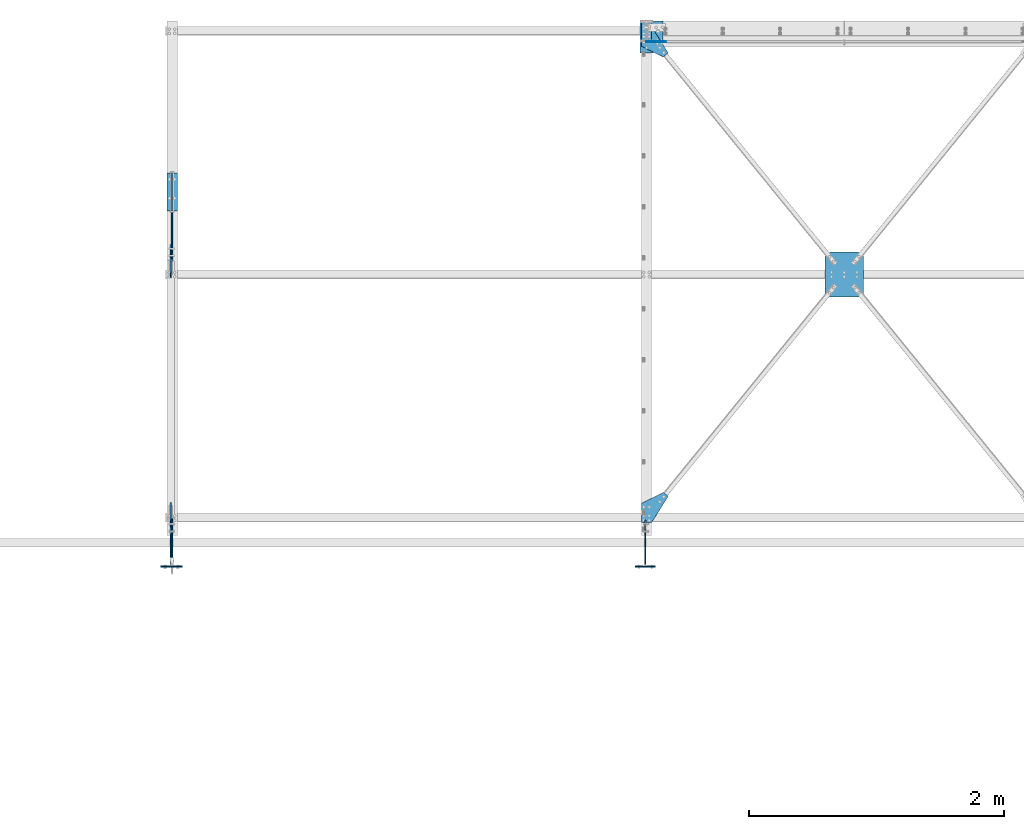
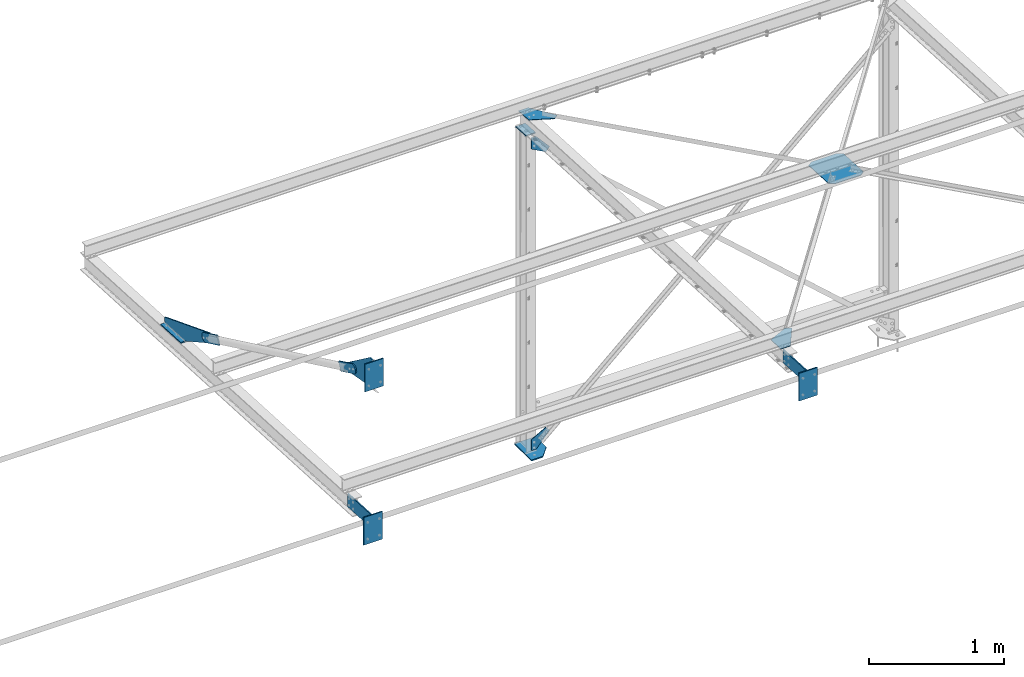
# One storey, part 100 of 496: 17 beams, 11 elements without a shape of their own.
"""IFC2X3 building model written with IfcOpenShell, lengths in millimetres."""

from ifc_helpers import new_model, si_unit, frame, frame_2d, origin_with_axes, origin_2d_with_axis, place, context, subcontext, project, spatial, polyline, circle_curve, parameter, trimmed, segment, composite_curve, rectangle, outline, extrude, material, type_object, element, aggregate, save


model = new_model("IFC2X3")

# Units and contexts
model_context = context("Model", 3, precision=1e-05, world=origin_with_axes())
body_context = subcontext(model_context, "Body", "Model", "MODEL_VIEW")
ifc_project = project(units=[si_unit("LENGTHUNIT", "METRE", prefix="MILLI"), si_unit("AREAUNIT", "SQUARE_METRE"), si_unit("VOLUMEUNIT", "CUBIC_METRE"), si_unit("MASSUNIT", "GRAM", prefix="KILO"), si_unit("TIMEUNIT", "SECOND"), si_unit("PLANEANGLEUNIT", "RADIAN"), si_unit("SOLIDANGLEUNIT", "STERADIAN"), si_unit("THERMODYNAMICTEMPERATUREUNIT", "DEGREE_CELSIUS"), si_unit("LUMINOUSINTENSITYUNIT", "LUMEN")], contexts=[model_context])

# Site, building, storey
site_placement = place(None, origin_with_axes())
site = spatial("IfcSite", under=ifc_project, at=site_placement, CompositionType="ELEMENT")
building_placement = place(site_placement, origin_with_axes())
building = spatial("IfcBuilding", under=site, at=building_placement, Name="Undefined", CompositionType="ELEMENT")
storey_placement = place(building_placement, origin_with_axes())
storey = spatial("IfcBuildingStorey", under=building, at=storey_placement, Name="Undefined", CompositionType="ELEMENT", Elevation=0.0)

# Assembly, beams
assembly_1_placement = place(storey_placement, origin_with_axes())
assembly_1 = element("IfcElementAssembly", 1, at=assembly_1_placement, inside=storey, AssemblyPlace="NOTDEFINED", PredefinedType="NOTDEFINED")
ifc_material_1 = material(Name="Undefined/S235-E24")
beam_type_1 = type_object("IfcBeamType", PredefinedType="NOTDEFINED")
beam_1_placement = place(assembly_1_placement, frame((25175.0000293075, 27344.6103668849, 3273.48983429776), z_axis=(1.0, 0.0, 0.0), x_axis=(0.0, -0.431020271960788, -0.902342243917932)))
beam_1 = element("IfcBeam", 2, at=beam_1_placement, type_object=beam_type_1, material=ifc_material_1, context=body_context, shape_type="SweptSolid", body=[
    extrude(outline(composite_curve([segment(polyline([(0.0, 0.0), (80.00000000008, 8.00355337560177e-11), (80.0000000002909, 219.999999998219)]), True, "CONTINUOUS"), segment(trimmed(circle_curve(frame_2d((40.0000000002909, 219.999999998257), x_axis=(1.0, 0.0)), 40.0), [parameter(0.0)], [parameter(1.57079632679722)], True, "PARAMETER"), True, "CONTINUOUS"), segment(trimmed(circle_curve(frame_2d((40.0000000002909, 219.999999998257), x_axis=(0.0, 1.0)), 40.0), [parameter(0.0)], [parameter(1.57079632679236)], True, "PARAMETER"), True, "CONTINUOUS"), segment(polyline([(2.58576339826929e-10, 219.999999998304), (0.0, 0.0)]), True, "CONTINUOUS")], self_intersect=True)), frame((0.0, 0.0, -5.0), z_axis=(0.0, 0.0, 1.0), x_axis=(1.0, 0.0, 0.0)), (0.0, 0.0, 1.0), 10.0),
])
beam_2_placement = place(assembly_1_placement, frame((25175.0000297447, 25546.3609697589, 4132.45653951192), z_axis=(-1.0, 0.0, 0.0), x_axis=(0.0, -0.431020271960788, -0.902342243917932)))
beam_2 = element("IfcBeam", 3, at=beam_2_placement, type_object=beam_type_1, material=ifc_material_1, context=body_context, shape_type="SweptSolid", body=[
    extrude(outline(composite_curve([segment(polyline([(0.0, 0.0), (80.00000000008, 8.00355337560177e-11), (80.0000000002909, 219.999999998219)]), True, "CONTINUOUS"), segment(trimmed(circle_curve(frame_2d((40.0000000002909, 219.999999998257), x_axis=(1.0, 0.0)), 40.0), [parameter(0.0)], [parameter(1.57079632679249)], True, "PARAMETER"), True, "CONTINUOUS"), segment(trimmed(circle_curve(frame_2d((40.0000000002909, 219.999999998257), x_axis=(0.0, 1.0)), 40.0), [parameter(0.0)], [parameter(1.57079632679703)], True, "PARAMETER"), True, "CONTINUOUS"), segment(polyline([(2.58576339826929e-10, 219.999999998304), (0.0, 0.0)]), True, "CONTINUOUS")], self_intersect=True)), frame((0.0, 0.0, -5.0), z_axis=(0.0, 0.0, 1.0), x_axis=(1.0, 0.0, 0.0)), (0.0, 0.0, 1.0), 10.0),
])
aggregate(assembly_1, [beam_1, beam_2])

# Assembly, beam
assembly_2_placement = place(storey_placement, origin_with_axes())
assembly_2 = element("IfcElementAssembly", 4, at=assembly_2_placement, inside=storey, AssemblyPlace="NOTDEFINED", PredefinedType="NOTDEFINED")
beam_type_2 = type_object("IfcBeamType", PredefinedType="NOTDEFINED")
beam_3_placement = place(assembly_2_placement, frame((29026.3497644049, 29157.4999999965, 2481.02868492766), z_axis=(0.0, 1.0, 0.0), x_axis=(-0.872821254162568, 0.0, 0.488040017090896)))
beam_3 = element("IfcBeam", 5, at=beam_3_placement, type_object=beam_type_2, material=ifc_material_1, context=body_context, shape_type="SweptSolid", body=[
    extrude(outline(polyline([(0.0, 0.0), (141.32307433863, 1.14596332423389e-10), (190.127075192879, 87.282104492615), (154.341445920723, 107.291732788459), (-10.885918618198, 48.8027305602627), (0.0, 0.0)])), frame((0.0, 0.0, -2.5), z_axis=(0.0, 0.0, 1.0), x_axis=(1.0, 0.0, 0.0)), (0.0, 0.0, 1.0), 5.0),
])
aggregate(assembly_2, [beam_3])

assembly_3_placement = place(storey_placement, origin_with_axes())
assembly_3 = element("IfcElementAssembly", 6, at=assembly_3_placement, inside=storey, AssemblyPlace="NOTDEFINED", PredefinedType="NOTDEFINED")
beam_4_placement = place(assembly_3_placement, frame((29059.6982862612, 29157.4999999965, -43.2829862831731), z_axis=(0.0, 1.0, 0.0), x_axis=(-0.659944115054256, 0.0, -0.751314691061778)))
beam_4 = element("IfcBeam", 7, at=beam_4_placement, type_object=beam_type_2, material=ifc_material_1, context=body_context, shape_type="SweptSolid", body=[
    extrude(outline(polyline([(0.0, 0.0), (175.315383911144, -3.89263732358813e-10), (202.37309265144, 30.8039016720977), (127.24160766623, 96.7983245848591), (-5.98146963107502, 49.6409301758285), (0.0, 0.0)])), frame((0.0, 0.0, -2.5), z_axis=(0.0, 0.0, 1.0), x_axis=(1.0, 0.0, 0.0)), (0.0, 0.0, 1.0), 5.0),
])
aggregate(assembly_3, [beam_4])

assembly_4_placement = place(storey_placement, origin_with_axes())
assembly_4 = element("IfcElementAssembly", 8, at=assembly_4_placement, inside=storey, Name="POTEAU", AssemblyPlace="NOTDEFINED", PredefinedType="NOTDEFINED")
beam_type_3 = type_object("IfcBeamType", PredefinedType="NOTDEFINED")
beam_5_placement = place(assembly_4_placement, frame((28902.9999703023, 29316.656577794, 2668.75845304258), z_axis=(1.0, 0.0, 0.0), x_axis=(0.0, -0.998630934640935, 0.0523092379811918)))
beam_5 = element("IfcBeam", 9, at=beam_5_placement, type_object=beam_type_3, material=ifc_material_1, Name="PLAT", context=body_context, shape_type="SweptSolid", body=[
    extrude(rectangle(XDim=10.0, YDim=82.0, at=origin_2d_with_axis()), frame((152.999350769322, 0.0, 0.0), z_axis=(-1.0, 0.0, 0.0), x_axis=(0.0, -1.0, 0.0)), (0.0, 0.0, 1.0), 153.0),
])

assembly_5_placement = place(storey_placement, origin_with_axes())
assembly_5 = element("IfcElementAssembly", 10, at=assembly_5_placement, inside=storey, AssemblyPlace="NOTDEFINED", PredefinedType="NOTDEFINED")
ifc_material_2 = material(Name="Undefined/S275-E28")
beam_6_placement = place(assembly_5_placement, frame((25185.000028941, 27831.4545141659, 2916.78781044038), z_axis=(1.0, 0.0, 0.0), x_axis=(-6.99999093594944e-09, 0.998630934429248, -0.0523092420224877)))
beam_6 = element("IfcBeam", 11, at=beam_6_placement, type_object=beam_type_3, material=ifc_material_2, context=body_context, shape_type="SweptSolid", body=[
    extrude(rectangle(XDim=10.0, YDim=82.0, at=origin_2d_with_axis()), frame((300.0, 0.0, 0.0), z_axis=(-1.0, 0.0, 0.0), x_axis=(0.0, -1.0, 0.0)), (0.0, 0.0, 1.0), 300.0),
])

assembly_6_placement = place(storey_placement, origin_with_axes())
assembly_6 = element("IfcElementAssembly", 12, at=assembly_6_placement, inside=storey, AssemblyPlace="NOTDEFINED", PredefinedType="NOTDEFINED")
beam_type_4 = type_object("IfcBeamType", PredefinedType="NOTDEFINED")
beam_7_placement = place(assembly_6_placement, frame((30302.8720014022, 27187.3588080074, 2943.01587178461), z_axis=(-3.30331196424227e-10, 0.0523092382845414, 0.998630934625045), x_axis=(0.776487237630943, -0.629270284631704, 0.0329617759807083)))
beam_7 = element("IfcBeam", 13, at=beam_7_placement, type_object=beam_type_4, material=ifc_material_1, context=body_context, shape_type="SweptSolid", body=[
    extrude(outline(polyline([(0.0, 0.0), (50.0, 0.0), (222.851638792074, 140.272125243755), (233.144882200212, 189.201156615607), (49.9999999999545, 414.883178709286), (-7.53022504795808e-07, 414.883178709235), (-172.851669309595, 274.611022947967), (-183.144912717741, 225.681991576079), (0.0, 0.0)])), frame((0.0, 0.0, -2.5), z_axis=(0.0, 0.0, 1.0), x_axis=(1.0, 0.0, 0.0)), (0.0, 0.0, 1.0), 5.0),
])
aggregate(assembly_6, [beam_7])

assembly_7_placement = place(storey_placement, origin_with_axes())
assembly_7 = element("IfcElementAssembly", 14, at=assembly_7_placement, inside=storey, AssemblyPlace="NOTDEFINED", PredefinedType="NOTDEFINED")
beam_type_5 = type_object("IfcBeamType", PredefinedType="NOTDEFINED")
beam_8_placement = place(assembly_7_placement, frame((28861.9999396125, 25541.1572011736, 3031.74890578333), z_axis=(-3.30331196424227e-10, 0.0523092382845414, 0.998630934625045), x_axis=(0.0, -0.998630934640935, 0.0523092379811918)))
beam_8 = element("IfcBeam", 15, at=beam_8_placement, type_object=beam_type_5, material=ifc_material_1, context=body_context, shape_type="SweptSolid", body=[
    extrude(outline(polyline([(0.0, 0.0), (149.999999999138, -4.0381564758718e-10), (149.999999999014, 82.0000305173671), (-54.2889137268066, 211.461898803787), (-85.7955627438969, 172.637542724733), (0.0, 0.0)])), frame((0.0, 0.0, -2.5), z_axis=(0.0, 0.0, 1.0), x_axis=(1.0, 0.0, 0.0)), (0.0, 0.0, 1.0), 5.0),
])
aggregate(assembly_7, [beam_8])

assembly_8_placement = place(storey_placement, origin_with_axes())
assembly_8 = element("IfcElementAssembly", 16, at=assembly_8_placement, inside=storey, AssemblyPlace="NOTDEFINED", PredefinedType="NOTDEFINED")
beam_9_placement = place(assembly_8_placement, frame((28861.9999390707, 29273.8650059671, 2836.22611900135), z_axis=(-3.30331196424227e-10, 0.0523092382845414, 0.998630934625045), x_axis=(0.0, -0.998630934640935, 0.0523092379811918)))
beam_9 = element("IfcBeam", 17, at=beam_9_placement, type_object=beam_type_5, material=ifc_material_1, context=body_context, shape_type="SweptSolid", body=[
    extrude(outline(polyline([(0.0, 0.0), (149.999999999138, -4.0381564758718e-10), (235.797088621945, 172.637512207384), (204.29043579015, 211.461868286442), (3.75086528947577e-07, 81.9999694824219), (0.0, 0.0)])), frame((0.0, 0.0, -2.5), z_axis=(0.0, 0.0, 1.0), x_axis=(1.0, 0.0, 0.0)), (0.0, 0.0, 1.0), 5.0),
])
aggregate(assembly_8, [beam_9])

assembly_9_placement = place(storey_placement, origin_with_axes())
assembly_9 = element("IfcElementAssembly", 18, at=assembly_9_placement, inside=storey, AssemblyPlace="NOTDEFINED", PredefinedType="NOTDEFINED")
beam_type_6 = type_object("IfcBeamType", PredefinedType="NOTDEFINED")
beam_10_placement = place(assembly_9_placement, frame((28893.0000296668, 25044.9999028517, 3050.00032752536), z_axis=(1.0, 0.0, 0.0), x_axis=(0.0, 0.0, -1.0)))
beam_10 = element("IfcBeam", 19, at=beam_10_placement, type_object=beam_type_6, material=ifc_material_2, context=body_context, shape_type="SweptSolid", body=[
    extrude(rectangle(XDim=10.0, YDim=160.0, at=origin_2d_with_axis()), frame((249.999999999634, 3.6379788203266e-12, 0.0), z_axis=(-1.0, 0.0, 0.0), x_axis=(0.0, -1.0, 0.0)), (0.0, 0.0, 1.0), 250.0),
])

assembly_10_placement = place(storey_placement, origin_with_axes())
assembly_10 = element("IfcElementAssembly", 20, at=assembly_10_placement, inside=storey, AssemblyPlace="NOTDEFINED", PredefinedType="NOTDEFINED")
beam_11_placement = place(assembly_10_placement, frame((25185.0000296668, 25044.9999028564, 4430.00032752955), z_axis=(1.0, 0.0, 0.0), x_axis=(0.0, 0.0, -1.0)))
beam_11 = element("IfcBeam", 21, at=beam_11_placement, type_object=beam_type_6, material=ifc_material_2, context=body_context, shape_type="SweptSolid", body=[
    extrude(rectangle(XDim=10.0, YDim=160.0, at=origin_2d_with_axis()), frame((249.999999999634, 3.6379788203266e-12, 0.0), z_axis=(-1.0, 0.0, 0.0), x_axis=(0.0, -1.0, 0.0)), (0.0, 0.0, 1.0), 250.0),
])

assembly_11_placement = place(storey_placement, origin_with_axes())
assembly_11 = element("IfcElementAssembly", 22, at=assembly_11_placement, inside=storey, AssemblyPlace="NOTDEFINED", PredefinedType="NOTDEFINED")
beam_12_placement = place(assembly_11_placement, frame((25175.0000296668, 25044.9999028517, 3050.00032752536), z_axis=(1.0, 0.0, 0.0), x_axis=(0.0, 0.0, -1.0)))
beam_12 = element("IfcBeam", 23, at=beam_12_placement, type_object=beam_type_6, material=ifc_material_2, context=body_context, shape_type="SweptSolid", body=[
    extrude(rectangle(XDim=10.0, YDim=160.0, at=origin_2d_with_axis()), frame((249.999999999634, 3.6379788203266e-12, 0.0), z_axis=(-1.0, 0.0, 0.0), x_axis=(0.0, -1.0, 0.0)), (0.0, 0.0, 1.0), 250.0),
])

# Beam
beam_type_7 = type_object("IfcBeamType", PredefinedType="NOTDEFINED")
beam_13_placement = place(assembly_9_placement, frame((28893.0000296668, 25409.9999999954, 2898.42711388201), z_axis=(-1.0, 0.0, 0.0), x_axis=(0.0, -0.998630934640935, 0.0523092379811918)))
beam_13 = element("IfcBeam", 24, at=beam_13_placement, type_object=beam_type_7, material=ifc_material_1, context=body_context, shape_type="SweptSolid", body=[
    extrude(outline(polyline([(0.0, 0.0), (230.315322877854, 6.41193764749914e-10), (334.385864260355, -116.077178954362), (354.358612063246, -117.123367308813), (366.779327395761, 120.000000000726), (6.28570985818806, 120.000007629378), (0.0, 0.0)])), frame((0.0, 0.0, -5.0), z_axis=(0.0, 0.0, 1.0), x_axis=(1.0, 0.0, 0.0)), (0.0, 0.0, 1.0), 10.0),
])

aggregate(assembly_9, [beam_10, beam_13])

beam_14_placement = place(assembly_11_placement, frame((25175.0000296668, 25409.9999999954, 2898.42711388201), z_axis=(-1.0, 0.0, 0.0), x_axis=(0.0, -0.998630934640935, 0.0523092379811918)))
beam_14 = element("IfcBeam", 25, at=beam_14_placement, type_object=beam_type_7, material=ifc_material_1, context=body_context, shape_type="SweptSolid", body=[
    extrude(outline(polyline([(0.0, 0.0), (230.315322877854, 6.41193764749914e-10), (334.385864260355, -116.077178954362), (354.358612063246, -117.123367308813), (366.779327395761, 120.000000000726), (6.28570985818806, 120.000007629378), (0.0, 0.0)])), frame((0.0, 0.0, -5.0), z_axis=(0.0, 0.0, 1.0), x_axis=(1.0, 0.0, 0.0)), (0.0, 0.0, 1.0), 10.0),
])

aggregate(assembly_11, [beam_12, beam_14])

beam_type_8 = type_object("IfcBeamType", PredefinedType="NOTDEFINED")
beam_15_placement = place(assembly_10_placement, frame((25185.0000297773, 25420.0330477764, 4192.79936103159), z_axis=(-1.0, 0.0, 0.0), x_axis=(0.0, -0.431020271960788, -0.902342243917932)))
beam_15 = element("IfcBeam", 26, at=beam_15_placement, type_object=beam_type_8, material=ifc_material_1, context=body_context, shape_type="SweptSolid", body=[
    extrude(outline(polyline([(0.0, 0.0), (80.00000000008, 8.00355337560177e-11), (171.041168212265, 328.379669187176), (-54.5444107060048, 436.134674069577), (-76.0954360965479, 391.017608640192), (0.0, 0.0)])), frame((0.0, 0.0, -5.0), z_axis=(0.0, 0.0, 1.0), x_axis=(1.0, 0.0, 0.0)), (0.0, 0.0, 1.0), 10.0),
])

aggregate(assembly_10, [beam_11, beam_15])

beam_type_9 = type_object("IfcBeamType", PredefinedType="NOTDEFINED")
beam_16_placement = place(assembly_5_placement, frame((25185.0000292749, 27470.938273212, 3213.14697970708), z_axis=(1.0, 0.0, 0.0), x_axis=(0.0, -0.431020271960788, -0.902342243917932)))
beam_16 = element("IfcBeam", 27, at=beam_16_placement, type_object=beam_type_9, material=ifc_material_1, context=body_context, shape_type="SweptSolid", body=[
    extrude(outline(polyline([(0.0, 0.0), (80.00000000008, 8.00355337560177e-11), (107.409309387442, 451.129699704041), (-7.5594706531283, 728.225769037927), (-53.7421607967153, 709.064208979413), (0.0, 0.0)])), frame((0.0, 0.0, -5.0), z_axis=(0.0, 0.0, 1.0), x_axis=(1.0, 0.0, 0.0)), (0.0, 0.0, 1.0), 10.0),
])

aggregate(assembly_5, [beam_6, beam_16])

beam_type_10 = type_object("IfcBeamType", PredefinedType="NOTDEFINED")
beam_17_placement = place(assembly_4_placement, frame((29032.9999997605, 29320.0000661869, -195.0), z_axis=(0.0, 0.0, 1.0), x_axis=(-1.0, 0.0, 0.0)))
beam_17 = element("IfcBeam", 28, at=beam_17_placement, type_object=beam_type_10, material=ifc_material_1, context=body_context, shape_type="SweptSolid", body=[
    extrude(outline(polyline([(0.0, 0.0), (180.000061035156, 0.0), (180.0, 250.0), (80.0, 250.0), (0.0, 159.999984741211), (0.0, 0.0)])), frame((0.0, 0.0, -5.0), z_axis=(0.0, 0.0, 1.0), x_axis=(1.0, 0.0, 0.0)), (0.0, 0.0, 1.0), 10.0),
])

aggregate(assembly_4, [beam_5, beam_17])

save(model, "model.ifc")
